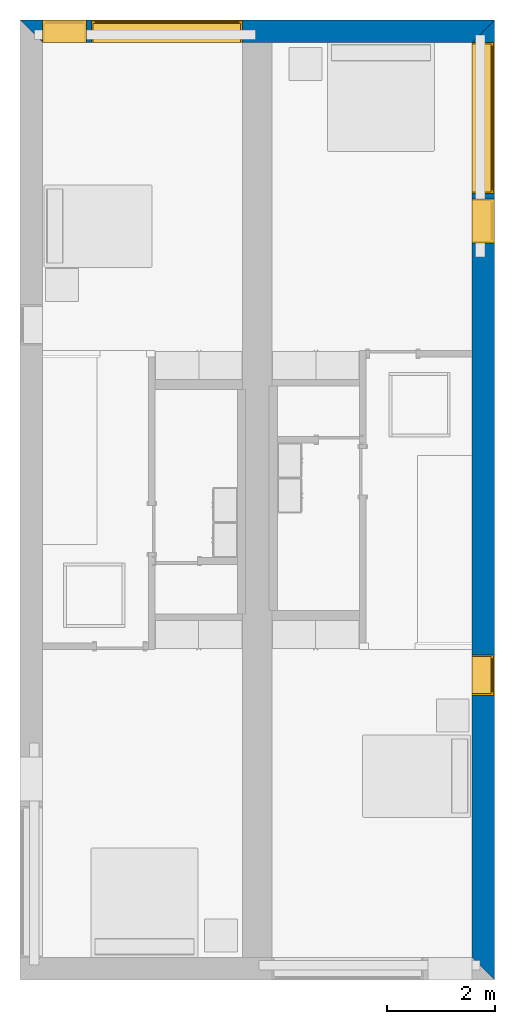
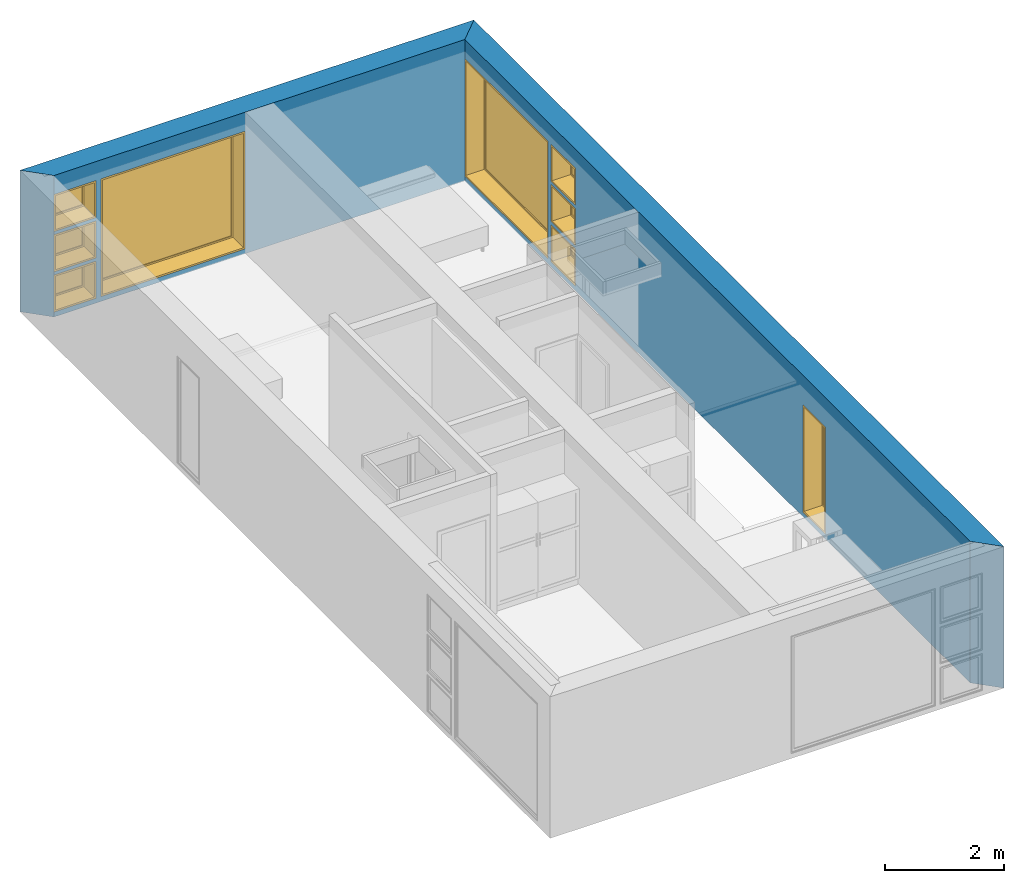
# One storey, part 4 of 14: 9 windows, 2 walls, 9 openings.
"""IFC2X3 building model written with IfcOpenShell, lengths in metres."""

import ifcopenshell
import ifcopenshell.guid

model = None  # the IFC model being written
_history = None  # IfcOwnerHistory: only IFC2X3 demands one
_inside = {}  # id of a spatial element -> (the spatial element, [elements in it])
_under = {}  # id of a project, library or spatial element -> (it, [spatial elements below it])
_declared = {}  # id of a project -> (the project, [libraries it declares])
_typed = {}  # id of a type object -> (the type object, [elements of that type])
_made_of = {}  # id of a material, layer set ... -> (it, [elements and type objects made of it])


def new_model(schema):
    """Start an empty IFC model of exactly this schema.

    Asked for "IFC4X3", IfcOpenShell would pick the latest addendum, in which some entities
    have other attributes; the version numbers below select the first issue.
    IFC2X3 requires an IfcOwnerHistory on every rooted entity: one is made here for all.
    """
    global model, _history
    if schema == "IFC4X3":
        model = ifcopenshell.file(schema_version=(4, 3, 0, 0))
    else:
        model = ifcopenshell.file(schema=schema)
    _inside.clear()
    _under.clear()
    _declared.clear()
    _typed.clear()
    _made_of.clear()
    _history = None
    if model.schema == "IFC2X3":
        org = make("IfcOrganization", Name="unknown")
        user = make(
            "IfcPersonAndOrganization",
            ThePerson=make("IfcPerson", FamilyName="unknown"),
            TheOrganization=org,
        )
        app = make(
            "IfcApplication",
            ApplicationDeveloper=org,
            Version="unknown",
            ApplicationFullName="unknown",
            ApplicationIdentifier="unknown",
        )
        _history = make(
            "IfcOwnerHistory",
            OwningUser=user,
            OwningApplication=app,
            ChangeAction="ADDED",
            CreationDate=0,
        )
    return model


def make(cls, **values):
    """One entity of the class cls with the attributes given. An attribute that is None is left unset."""
    return model.create_entity(
        cls, **{name: value for name, value in values.items() if value is not None}
    )


def entity(cls, *values):
    """Any entity or typed value of the class cls, its attributes in the order of the schema. None: left unset."""
    e = model.create_entity(cls)
    for i, value in enumerate(values):
        if value is not None:
            e[i] = value
    return e


def rooted(cls, **values):
    """An entity with a GlobalId (a new one), such as an element, a storey or a relation."""
    return make(cls, GlobalId=ifcopenshell.guid.new(), OwnerHistory=_history, **values)


def si_unit(unit_type, name, prefix=None):
    """IfcSIUnit, for example si_unit("LENGTHUNIT", "METRE", prefix="MILLI")."""
    return make("IfcSIUnit", UnitType=unit_type, Prefix=prefix, Name=name)


def converted_unit(unit_type, name, factor, base, dimensions=None, offset=None):
    """IfcConversionBasedUnit, such as the inch: factor (a typed value) times the base unit."""
    return make(
        "IfcConversionBasedUnit"
        if offset is None
        else "IfcConversionBasedUnitWithOffset",
        ConversionOffset=offset,
        Dimensions=None
        if dimensions is None
        else entity("IfcDimensionalExponents", *dimensions),
        UnitType=unit_type,
        Name=name,
        ConversionFactor=make(
            "IfcMeasureWithUnit", ValueComponent=factor, UnitComponent=base
        ),
    )


def assignment(units):
    """IfcUnitAssignment: the units of a project."""
    return None if units is None else make("IfcUnitAssignment", Units=units)


def point(xyz):
    """IfcCartesianPoint."""
    return None if xyz is None else make("IfcCartesianPoint", Coordinates=xyz)


def direction(xyz):
    """IfcDirection."""
    return None if xyz is None else make("IfcDirection", DirectionRatios=xyz)


def frame(location, z_axis=None, x_axis=None):
    """IfcAxis2Placement3D, a coordinate frame: its origin and axes. An axis left out is left unset."""
    return make(
        "IfcAxis2Placement3D",
        Location=point(location),
        Axis=direction(z_axis),
        RefDirection=direction(x_axis),
    )


def frame_2d(location, x_axis=None):
    """IfcAxis2Placement2D, a coordinate frame in the plane: its origin and x axis."""
    return make(
        "IfcAxis2Placement2D", Location=point(location), RefDirection=direction(x_axis)
    )


def origin():
    """The frame at (0, 0, 0) with its axes left unset."""
    return frame((0.0, 0.0, 0.0))


def origin_2d_with_axis():
    """The frame at (0, 0) in the plane with the x axis (1, 0) written out."""
    return frame_2d((0.0, 0.0), x_axis=(1.0, 0.0))


def place(relative_to, where):
    """IfcLocalPlacement: puts the frame where relative to a parent placement (None: the world)."""
    return make(
        "IfcLocalPlacement", PlacementRelTo=relative_to, RelativePlacement=where
    )


def context(
    kind, dimensions, precision=None, world=None, true_north=None, identifier=None
):
    """IfcGeometricRepresentationContext, for example the 3D "Model" context."""
    return make(
        "IfcGeometricRepresentationContext",
        ContextIdentifier=identifier,
        ContextType=kind,
        CoordinateSpaceDimension=dimensions,
        Precision=precision,
        WorldCoordinateSystem=world,
        TrueNorth=true_north,
    )


def project(units=None, contexts=None):
    """IfcProject with its units and contexts."""
    return rooted(
        "IfcProject",
        Name="project",
        RepresentationContexts=contexts,
        UnitsInContext=assignment(units),
    )


def spatial(cls, under=None, at=None, **own):
    """A site, building, storey or space (cls), placed at a placement, below another one or the project."""
    s = rooted(cls, ObjectPlacement=at, **own)
    if under is not None:
        _under.setdefault(under.id(), (under, []))[1].append(s)
    return s


def polyline(points):
    """IfcPolyline through the points."""
    return make("IfcPolyline", Points=[point(p) for p in points])


def profile(cls, at=None, kind="AREA", **sizes):
    """A parametric profile (cls). Its sizes go by their IFC names, for example OverallWidth=200.0."""
    return make(cls, ProfileType=kind, Position=at, **sizes)


def rectangle(**sizes):
    """IfcRectangleProfileDef."""
    return profile("IfcRectangleProfileDef", **sizes)


def outline(outer, holes=None, kind="AREA"):
    """IfcArbitraryClosedProfileDef: a profile drawn as a closed curve; with holes, ...WithVoids."""
    if holes is None:
        return make("IfcArbitraryClosedProfileDef", ProfileType=kind, OuterCurve=outer)
    return make(
        "IfcArbitraryProfileDefWithVoids",
        ProfileType=kind,
        OuterCurve=outer,
        InnerCurves=holes,
    )


def extrude(swept, where, along, depth):
    """IfcExtrudedAreaSolid: the profile swept, set in the frame where, extruded along a direction by depth."""
    return make(
        "IfcExtrudedAreaSolid",
        SweptArea=swept,
        Position=where,
        ExtrudedDirection=direction(along),
        Depth=depth,
    )


def shape(context_of_items, identifier, shape_type, items):
    """IfcShapeRepresentation: the items that make up one representation, for example the "Body"."""
    return make(
        "IfcShapeRepresentation",
        ContextOfItems=context_of_items,
        RepresentationIdentifier=identifier,
        RepresentationType=shape_type,
        Items=items,
    )


def source(mapping_origin, context_of_items, identifier, shape_type, items):
    """IfcRepresentationMap: a shape defined once, which mapped items show again and again."""
    return make(
        "IfcRepresentationMap",
        MappingOrigin=mapping_origin,
        MappedRepresentation=shape(context_of_items, identifier, shape_type, items),
    )


def transform(
    local_origin,
    x_axis=None,
    y_axis=None,
    z_axis=None,
    scale=None,
    scale2=None,
    scale3=None,
    uniform=True,
):
    """IfcCartesianTransformationOperator3D, or its non-uniform kind. x_axis, y_axis, z_axis: its Axis1, 2, 3."""
    if uniform:
        return make(
            "IfcCartesianTransformationOperator3D",
            Axis1=direction(x_axis),
            Axis2=direction(y_axis),
            LocalOrigin=point(local_origin),
            Scale=scale,
            Axis3=direction(z_axis),
        )
    return make(
        "IfcCartesianTransformationOperator3DnonUniform",
        Axis1=direction(x_axis),
        Axis2=direction(y_axis),
        LocalOrigin=point(local_origin),
        Scale=scale,
        Axis3=direction(z_axis),
        Scale2=scale2,
        Scale3=scale3,
    )


def mapped(mapping_source, mapping_target):
    """IfcMappedItem: shows the shape of a source again, moved by a transform."""
    return make(
        "IfcMappedItem", MappingSource=mapping_source, MappingTarget=mapping_target
    )


def material(Name=None, Category=None):
    """IfcMaterial."""
    return make("IfcMaterial", Name=Name, Category=Category)


def layer(
    of_material, thickness, ventilated=None, Name=None, Category=None, Priority=None
):
    """IfcMaterialLayer: one layer of a wall or slab, of a material (None: an air gap)."""
    return make(
        "IfcMaterialLayer",
        Material=of_material,
        LayerThickness=thickness,
        IsVentilated=ventilated,
        Name=Name,
        Category=Category,
        Priority=Priority,
    )


def layer_set(layers, Name=None):
    """IfcMaterialLayerSet."""
    return make("IfcMaterialLayerSet", MaterialLayers=layers, LayerSetName=Name)


def layer_usage(for_layer_set, set_direction, sense, offset, extent=None):
    """IfcMaterialLayerSetUsage: how a layer set lies in its element."""
    return make(
        "IfcMaterialLayerSetUsage",
        ForLayerSet=for_layer_set,
        LayerSetDirection=set_direction,
        DirectionSense=sense,
        OffsetFromReferenceLine=offset,
        ReferenceExtent=extent,
    )


def made_of(thing, what):
    """Note that an element or type object is made of a material, layer set ...; save() writes the relation."""
    if what is not None:
        _made_of.setdefault(what.id(), (what, []))[1].append(thing)
    return thing


def type_object(cls, material=None, **own):
    """A type object (cls), such as IfcWallType, which elements share."""
    return made_of(rooted(cls, **own), material)


def type_shapes(of_type, sources):
    """Give a type object the sources (RepresentationMaps) that its elements show as mapped items."""
    of_type.RepresentationMaps = sources


def element(
    cls,
    number,
    at=None,
    inside=None,
    cuts=None,
    type_object=None,
    material=None,
    context=None,
    identifier="Body",
    shape_type=None,
    held_by="IfcProductDefinitionShape",
    body=None,
    shapes=None,
    **own,
):
    """One element of the class cls, such as IfcWall. Its Tag is "e" and its number.

    at: its placement. inside: the storey or other place that contains it. cuts: it is an
    opening in that element (IfcRelVoidsElement). A single representation is given by context,
    identifier, shape_type and body (its items); several are given by shapes. held_by: the class
    of the entity that holds the representations. save() writes the other relations.
    """
    e = rooted(cls, Tag="e%d" % number, ObjectPlacement=at, **own)
    if body is not None:
        shapes = [shape(context, identifier, shape_type, body)]
    if shapes is not None:
        e.Representation = make(held_by, Representations=shapes)
    if inside is not None:
        _inside.setdefault(inside.id(), (inside, []))[1].append(e)
    if cuts is not None:
        rooted(
            "IfcRelVoidsElement", RelatingBuildingElement=cuts, RelatedOpeningElement=e
        )
    if type_object is not None:
        _typed.setdefault(type_object.id(), (type_object, []))[1].append(e)
    return made_of(e, material)


def fill(opening, filler):
    """IfcRelFillsElement: the door or window that sits in an opening."""
    return rooted(
        "IfcRelFillsElement",
        RelatingOpeningElement=opening,
        RelatedBuildingElement=filler,
    )


def aggregate(whole, parts):
    """IfcRelAggregates: a whole, such as a stair, and the parts it consists of."""
    return rooted("IfcRelAggregates", RelatingObject=whole, RelatedObjects=parts)


def save(model, path):
    """Write the relations noted so far, then the file.

    IfcRelAggregates (storeys below a building ...), IfcRelContainedInSpatialStructure (elements
    in a storey), IfcRelDefinesByType, IfcRelAssociatesMaterial and IfcRelDeclares: one each for
    every whole, place, type object, material and project.
    """
    for whole, parts in _under.values():
        aggregate(whole, parts)
    for where, things in _inside.values():
        rooted(
            "IfcRelContainedInSpatialStructure",
            RelatedElements=things,
            RelatingStructure=where,
        )
    for kind, things in _typed.values():
        rooted("IfcRelDefinesByType", RelatedObjects=things, RelatingType=kind)
    for what, things in _made_of.values():
        rooted("IfcRelAssociatesMaterial", RelatedObjects=things, RelatingMaterial=what)
    for by, libraries in _declared.values():
        rooted("IfcRelDeclares", RelatingContext=by, RelatedDefinitions=libraries)
    model.write(path)


model = new_model("IFC2X3")

# Units and contexts
model_context = context("Model", 3, precision=1e-09, world=origin())
plan_context = context("Plan", 3, precision=1e-09, world=origin())
ifc_project = project(units=[si_unit("LENGTHUNIT", "METRE"), si_unit("AREAUNIT", "SQUARE_METRE"), si_unit("VOLUMEUNIT", "CUBIC_METRE"), converted_unit("PLANEANGLEUNIT", "DEGREE", entity("IfcRatioMeasure", 0.01745329251994328), si_unit("PLANEANGLEUNIT", "RADIAN"), dimensions=[0, 0, 0, 0, 0, 0, 0]), si_unit("TIMEUNIT", "SECOND")], contexts=[model_context, plan_context])

# Site, building, storey
site_placement = place(None, origin())
site = spatial("IfcSite", under=ifc_project, at=site_placement, CompositionType="ELEMENT")
building_placement = place(site_placement, origin())
building = spatial("IfcBuilding", under=site, at=building_placement, CompositionType="ELEMENT")
storey_placement = place(building_placement, frame((0.0, 0.0, 3.100000000000378)))
storey = spatial("IfcBuildingStorey", under=building, at=storey_placement, Name="Level 2", CompositionType="ELEMENT", Elevation=3.100000000000378)

# Wall, openings, windows
ifc_material_1 = material(Name="Masonry - Brick")
ifc_layer_1 = layer(ifc_material_1, 0.092)
ifc_material_2 = material(Name="Misc. Air Layers - Air Space")
ifc_layer_2 = layer(ifc_material_2, 0.025)
ifc_material_3 = material(Name="Insulation / Thermal Barriers - Rigid insulation")
ifc_layer_3 = layer(ifc_material_3, 0.05)
ifc_material_4 = material(Name="Masonry - Concrete Block")
ifc_layer_4 = layer(ifc_material_4, 0.193)
ifc_material_5 = material(Name="Metal - Stud Layer")
ifc_layer_5 = layer(ifc_material_5, 0.041)
ifc_material_6 = material(Name="Plasterboard")
ifc_layer_6 = layer(ifc_material_6, 0.016)
ifc_layer_set = layer_set([ifc_layer_1, ifc_layer_2, ifc_layer_3, ifc_layer_4, ifc_layer_5, ifc_layer_6], Name="Basic Wall:Exterior - Brick on Block")
ifc_layer_usage = layer_usage(ifc_layer_set, "AXIS2", "NEGATIVE", 0.2085000000000001)
wall_1_placement = place(storey_placement, frame((8.5915, 0.0, 0.0), z_axis=(0.0, 0.0, 1.0), x_axis=(0.0, -1.0, 0.0)))
wall_1 = element("IfcWallStandardCase", 1, at=wall_1_placement, inside=storey, material=ifc_layer_usage, Name="Basic Wall:Exterior - Brick on Block", ObjectType="Basic Wall:Exterior - Brick on Block", context=model_context, shape_type="SweptSolid", body=[
    extrude(outline(polyline([(17.38299999999997, -0.2084999999999999), (17.79999999999997, 0.2085000000000002), (0.0, 0.2085000000000002), (0.4169999999999991, -0.2085000000000007), (6.125999999999979, -0.2084999999999999), (6.24999999999998, -0.2084999999999997), (17.38299999999997, -0.2084999999999999)])), origin(), (0.0, 0.0, 1.0), 2.900000000000012),
])
opening_1_placement = place(wall_1_placement, frame((11.774, -0.2085000000000172, 0.09999999999981862)))
opening_1 = element("IfcOpeningElement", 2, at=opening_1_placement, cuts=wall_1, ObjectType="Opening", context=model_context, shape_type="SweptSolid", body=[
    extrude(rectangle(XDim=2.199999999999996, YDim=0.7499999999999996, at=frame_2d((1.099999999999999, 0.3749999999999987), x_axis=(1.0, 0.0))), frame((0.0, 0.0, 0.0), z_axis=(0.0, 1.0, 0.0), x_axis=(0.0, 0.0, 1.0)), (0.0, 0.0, 1.0), 0.4170000000000001),
])
opening_2_placement = place(wall_1_placement, frame((3.317000000000042, -0.2085000000000054, 0.9254999999998184)))
opening_2 = element("IfcOpeningElement", 3, at=opening_2_placement, cuts=wall_1, ObjectType="Opening", context=model_context, shape_type="SweptSolid", body=[
    extrude(rectangle(XDim=0.7590000000000007, YDim=0.8189999999999998, at=frame_2d((0.3795000000000003, 0.4094999999999999), x_axis=(-1.0, 0.0))), frame((0.0, 0.0, 0.0), z_axis=(0.0, 1.0, 0.0), x_axis=(0.0, 0.0, 1.0)), (0.0, 0.0, 1.0), 0.4170000000000001),
])
opening_3_placement = place(wall_1_placement, frame((0.4170000000000265, -0.2084999999999953, 0.09999999999981862)))
opening_3 = element("IfcOpeningElement", 4, at=opening_3_placement, cuts=wall_1, ObjectType="Opening", context=model_context, shape_type="SweptSolid", body=[
    extrude(rectangle(XDim=2.409999999999996, YDim=2.8, at=frame_2d((1.204999999999998, 1.4), x_axis=(1.0, 0.0))), frame((0.0, 0.0, 0.0), z_axis=(0.0, 1.0, 0.0), x_axis=(0.0, 0.0, 1.0)), (0.0, 0.0, 1.0), 0.4170000000000001),
])
opening_4_placement = place(wall_1_placement, frame((3.317000000000027, -0.2085000000000039, 1.750999999999819)))
opening_4 = element("IfcOpeningElement", 5, at=opening_4_placement, cuts=wall_1, ObjectType="Opening", context=model_context, shape_type="SweptSolid", body=[
    extrude(rectangle(XDim=0.7589999999999981, YDim=0.8189999999999995, at=frame_2d((0.379499999999999, 0.4094999999999998), x_axis=(1.0, 0.0))), frame((0.0, 0.0, 0.0), z_axis=(0.0, 1.0, 0.0), x_axis=(0.0, 0.0, 1.0)), (0.0, 0.0, 1.0), 0.4170000000000001),
])
opening_5_placement = place(wall_1_placement, frame((3.317000000000027, -0.2085000000000039, 0.09999999999981862)))
opening_5 = element("IfcOpeningElement", 6, at=opening_5_placement, cuts=wall_1, ObjectType="Opening", context=model_context, shape_type="SweptSolid", body=[
    extrude(rectangle(XDim=0.7589999999999981, YDim=0.8189999999999995, at=frame_2d((0.3794999999999993, 0.4094999999999998), x_axis=(1.0, 0.0))), frame((0.0, 0.0, 0.0), z_axis=(0.0, 1.0, 0.0), x_axis=(0.0, 0.0, 1.0)), (0.0, 0.0, 1.0), 0.4170000000000001),
])
window_style_1 = type_object("IfcWindowStyle", Name="819mm x 759mm", ConstructionType="NOTDEFINED", OperationType="NOTDEFINED", ParameterTakesPrecedence=False, Sizeable=False)
shared_shape_1 = source(origin(), model_context, "Body", "SweptSolid", [
    extrude(rectangle(XDim=0.01199999999999998, YDim=0.6929999999999971, at=origin_2d_with_axis()), frame((0.4095000000000068, 0.3759999999999988, 0.06299999999998514), z_axis=(0.0, 0.0, 1.0), x_axis=(0.0, -1.0, 0.0)), (0.0, 0.0, 1.0), 0.6330000000000073),
    extrude(outline(polyline([(-0.3904999999999999, -0.3605000000000028), (0.3904999999999999, -0.3605000000000028), (0.3904999999999999, 0.3605000000000027), (-0.3904999999999999, 0.3605000000000027), (-0.3904999999999999, -0.3605000000000028)]), holes=[polyline([(-0.3464999999999996, -0.3165000000000033), (-0.3464999999999996, 0.316500000000004), (0.3464999999999974, 0.316500000000004), (0.3464999999999974, -0.3165000000000033), (-0.3464999999999996, -0.3165000000000033)])]), frame((0.4095000000000078, 0.3539999999999714, 0.3794999999999891), z_axis=(0.0, 1.0, 0.0), x_axis=(1.0, 0.0, 0.0)), (0.0, 0.0, 1.0), 0.04400000000002743),
    extrude(outline(polyline([(-0.4094999999999998, -0.3794999999999972), (0.4094999999999998, -0.3794999999999972), (0.4094999999999998, 0.3794999999999971), (-0.4094999999999998, 0.3794999999999971), (-0.4094999999999998, -0.3794999999999972)]), holes=[polyline([(-0.3905000000000011, -0.3604999999999823), (-0.3905000000000012, 0.3605000000000231), (0.3904999999999986, 0.3605000000000231), (0.3904999999999987, -0.3604999999999823), (-0.3905000000000011, -0.3604999999999823)])]), frame((0.4095000000000091, 0.3539999999999714, 0.3795000000000096), z_axis=(0.0, 1.0, 0.0), x_axis=(1.0, 0.0, 0.0)), (0.0, 0.0, 1.0), 0.06300000000002744),
    extrude(outline(polyline([(-0.4095000000000002, -0.3794999999999967), (0.4095000000000002, -0.3794999999999967), (0.4095000000000002, 0.3794999999999966), (-0.4095000000000002, 0.3794999999999966), (-0.4095000000000002, -0.3794999999999967)]), holes=[polyline([(-0.3774999999999999, -0.3474999999999832), (-0.3774999999999999, 0.3475000000000212), (0.3775000000000001, 0.3475000000000212), (0.3775000000000001, -0.3474999999999832), (-0.3774999999999999, -0.3474999999999832)])]), frame((0.4095000000000096, 0.0, 0.379500000000009), z_axis=(0.0, 1.0, 0.0), x_axis=(1.0, 0.0, 0.0)), (0.0, 0.0, 1.0), 0.3539999999999727),
])
type_shapes(window_style_1, [shared_shape_1])
window_1_placement = place(opening_5_placement, origin())
window_1 = element("IfcWindow", 7, at=window_1_placement, inside=storey, type_object=window_style_1, ObjectType="819mm x 759mm", OverallHeight=0.7589999999999986, OverallWidth=0.8189999999999995, context=model_context, shape_type="MappedRepresentation", body=[
    mapped(shared_shape_1, transform((0.0, 0.0, 0.0), scale=1.0)),
])
fill(opening_5, window_1)
window_2_placement = place(opening_4_placement, origin())
window_2 = element("IfcWindow", 8, at=window_2_placement, inside=storey, type_object=window_style_1, ObjectType="819mm x 759mm", OverallHeight=0.758999999999998, OverallWidth=0.8189999999999995, context=model_context, shape_type="MappedRepresentation", body=[
    mapped(shared_shape_1, transform((0.0, 0.0, 0.0), scale=1.0)),
])
fill(opening_4, window_2)
window_style_2 = type_object("IfcWindowStyle", Name="2800mm x 2410mm", ConstructionType="NOTDEFINED", OperationType="NOTDEFINED", ParameterTakesPrecedence=False, Sizeable=False)
shared_shape_2 = source(origin(), model_context, "Body", "SweptSolid", [
    extrude(rectangle(XDim=0.01199999999999998, YDim=2.673999999999997, at=origin_2d_with_axis()), frame((1.400000000000007, 0.3759999999999956, 0.06299999999998514), z_axis=(0.0, 0.0, 1.0), x_axis=(0.0, -1.0, 0.0)), (0.0, 0.0, 1.0), 2.284000000000005),
    extrude(outline(polyline([(-1.381, -1.186000000000001), (1.381, -1.186000000000001), (1.381, 1.186000000000001), (-1.381, 1.186000000000001), (-1.381, -1.186000000000001)]), holes=[polyline([(-1.336999999999999, -1.142000000000002), (-1.336999999999999, 1.142000000000003), (1.336999999999997, 1.142000000000003), (1.336999999999997, -1.142000000000002), (-1.336999999999999, -1.142000000000002)])]), frame((1.400000000000008, 0.3539999999999681, 1.204999999999988), z_axis=(0.0, 1.0, 0.0), x_axis=(1.0, 0.0, 0.0)), (0.0, 0.0, 1.0), 0.04400000000002743),
    extrude(outline(polyline([(-1.4, -1.204999999999996), (1.4, -1.204999999999996), (1.4, 1.204999999999996), (-1.4, 1.204999999999996), (-1.4, -1.204999999999996)]), holes=[polyline([(-1.381000000000001, -1.185999999999981), (-1.381000000000001, 1.186000000000022), (1.380999999999999, 1.186000000000022), (1.380999999999999, -1.185999999999981), (-1.381000000000001, -1.185999999999981)])]), frame((1.400000000000009, 0.3539999999999681, 1.205000000000009), z_axis=(0.0, 1.0, 0.0), x_axis=(1.0, 0.0, 0.0)), (0.0, 0.0, 1.0), 0.06300000000002744),
    extrude(outline(polyline([(-1.4, -1.204999999999995), (1.4, -1.204999999999995), (1.4, 1.204999999999995), (-1.4, 1.204999999999995), (-1.4, -1.204999999999995)]), holes=[polyline([(-1.368, -1.172999999999982), (-1.368, 1.17300000000002), (1.368, 1.17300000000002), (1.367999999999999, -1.172999999999982), (-1.368, -1.172999999999982)])]), frame((1.40000000000001, 0.0, 1.205000000000008), z_axis=(0.0, 1.0, 0.0), x_axis=(1.0, 0.0, 0.0)), (0.0, 0.0, 1.0), 0.3539999999999727),
])
type_shapes(window_style_2, [shared_shape_2])
window_3_placement = place(opening_3_placement, origin())
window_3 = element("IfcWindow", 9, at=window_3_placement, inside=storey, type_object=window_style_2, ObjectType="2800mm x 2410mm", OverallHeight=2.409999999999996, OverallWidth=2.8, context=model_context, shape_type="MappedRepresentation", body=[
    mapped(shared_shape_2, transform((0.0, 0.0, 0.0), scale=1.0)),
])
fill(opening_3, window_3)
window_style_3 = type_object("IfcWindowStyle", Name="750mm x 2200mm", ConstructionType="NOTDEFINED", OperationType="NOTDEFINED", ParameterTakesPrecedence=False, Sizeable=False)
shared_shape_3 = source(origin(), model_context, "Body", "SweptSolid", [
    extrude(rectangle(XDim=0.01199999999999998, YDim=0.623999999999997, at=origin_2d_with_axis()), frame((0.375000000000007, 0.3759999999999988, 0.06299999999998514), z_axis=(0.0, 0.0, 1.0), x_axis=(0.0, -1.0, 0.0)), (0.0, 0.0, 1.0), 2.074000000000006),
    extrude(outline(polyline([(-0.3559999999999999, -1.081000000000002), (0.3559999999999999, -1.081000000000002), (0.3559999999999999, 1.081000000000002), (-0.3559999999999999, 1.081000000000002), (-0.3559999999999999, -1.081000000000002)]), holes=[polyline([(-0.3119999999999996, -1.037000000000002), (-0.3119999999999996, 1.037000000000003), (0.3119999999999975, 1.037000000000003), (0.3119999999999975, -1.037000000000002), (-0.3119999999999996, -1.037000000000002)])]), frame((0.3750000000000081, 0.3539999999999715, 1.099999999999989), z_axis=(0.0, 1.0, 0.0), x_axis=(1.0, 0.0, 0.0)), (0.0, 0.0, 1.0), 0.04400000000002743),
    extrude(outline(polyline([(-0.3749999999999997, -1.099999999999996), (0.3749999999999997, -1.099999999999996), (0.3749999999999997, 1.099999999999996), (-0.3749999999999997, 1.099999999999996), (-0.3749999999999997, -1.099999999999996)]), holes=[polyline([(-0.3560000000000012, -1.080999999999981), (-0.3560000000000013, 1.081000000000022), (0.3559999999999985, 1.081000000000022), (0.3559999999999986, -1.080999999999981), (-0.3560000000000012, -1.080999999999981)])]), frame((0.3750000000000094, 0.3539999999999715, 1.100000000000009), z_axis=(0.0, 1.0, 0.0), x_axis=(1.0, 0.0, 0.0)), (0.0, 0.0, 1.0), 0.06300000000002744),
    extrude(outline(polyline([(-0.3750000000000001, -1.099999999999996), (0.3750000000000001, -1.099999999999996), (0.3750000000000001, 1.099999999999996), (-0.3750000000000001, 1.099999999999996), (-0.3750000000000001, -1.099999999999996)]), holes=[polyline([(-0.3429999999999999, -1.067999999999982), (-0.3429999999999999, 1.06800000000002), (0.3430000000000001, 1.06800000000002), (0.3430000000000001, -1.067999999999982), (-0.3429999999999999, -1.067999999999982)])]), frame((0.3750000000000099, 0.0, 1.100000000000008), z_axis=(0.0, 1.0, 0.0), x_axis=(1.0, 0.0, 0.0)), (0.0, 0.0, 1.0), 0.3539999999999727),
])
type_shapes(window_style_3, [shared_shape_3])
window_4_placement = place(opening_1_placement, origin())
window_4 = element("IfcWindow", 10, at=window_4_placement, inside=storey, type_object=window_style_3, ObjectType="750mm x 2200mm", OverallHeight=2.199999999999997, OverallWidth=0.7499999999999984, context=model_context, shape_type="MappedRepresentation", body=[
    mapped(shared_shape_3, transform((0.0, 0.0, 0.0), scale=1.0)),
])
fill(opening_1, window_4)
window_style_4 = type_object("IfcWindowStyle", Name="819mm x 759mm", ConstructionType="NOTDEFINED", OperationType="NOTDEFINED", ParameterTakesPrecedence=False, Sizeable=False)
shared_shape_4 = source(origin(), model_context, "Body", "SweptSolid", [
    extrude(rectangle(XDim=0.01269999999999999, YDim=0.6919999999999978, at=origin_2d_with_axis()), frame((0.4095000000000003, 0.3757750000000001, 0.06350000000000397), z_axis=(0.0, 0.0, 1.0), x_axis=(0.0, 1.0, 0.0)), (0.0, 0.0, 1.0), 0.6320000000000041),
    extrude(outline(polyline([(-0.3904499999999989, -0.3604500000000012), (0.3904499999999989, -0.3604500000000012), (0.3904499999999989, 0.3604500000000012), (-0.3904499999999989, 0.3604500000000012), (-0.3904499999999989, -0.3604500000000012)]), holes=[polyline([(-0.3459999999999978, -0.3160000000000016), (-0.3459999999999978, 0.3160000000000026), (0.346, 0.3160000000000026), (0.346, -0.3160000000000016), (-0.3459999999999978, -0.3160000000000016)])]), frame((0.4094999999999992, 0.3535500000000001, 0.3795000000000066), z_axis=(0.0, 1.0, 0.0), x_axis=(1.0, 0.0, 0.0)), (0.0, 0.0, 1.0), 0.04445),
    extrude(outline(polyline([(-0.4094999999999992, -0.3795000000000012), (0.4094999999999992, -0.3795000000000012), (0.4094999999999992, 0.3795000000000012), (-0.4094999999999992, 0.3795000000000012), (-0.4094999999999992, -0.3795000000000012)]), holes=[polyline([(-0.3777500000000001, -0.3477499999999997), (-0.3777500000000001, 0.3477500000000008), (0.3777499999999982, 0.3477500000000008), (0.3777499999999982, -0.3477499999999997), (-0.3777500000000001, -0.3477499999999997)])]), frame((0.4095000000000007, 0.0, 0.3795000000000077), z_axis=(0.0, 1.0, 0.0), x_axis=(1.0, 0.0, 0.0)), (0.0, 0.0, 1.0), 0.3535500000000001),
    extrude(outline(polyline([(-0.3795000000000017, -0.4094999999999995), (0.3795000000000017, -0.4094999999999995), (0.3795000000000017, 0.4094999999999995), (-0.3795000000000017, 0.4094999999999995), (-0.3795000000000017, -0.4094999999999995)]), holes=[polyline([(-0.3604500000000023, -0.3904499999999987), (-0.3604500000000023, 0.3904499999999997), (0.3604500000000017, 0.3904499999999997), (0.3604500000000017, -0.3904499999999988), (-0.3604500000000023, -0.3904499999999987)])]), frame((0.4095000000000004, 0.3535500000000001, 0.3795000000000071), z_axis=(0.0, 1.0, 0.0), x_axis=(0.0, 0.0, -1.0)), (0.0, 0.0, 1.0), 0.06345),
])
type_shapes(window_style_4, [shared_shape_4])
window_5_placement = place(opening_2_placement, origin())
window_5 = element("IfcWindow", 11, at=window_5_placement, inside=storey, type_object=window_style_4, ObjectType="819mm x 759mm", OverallHeight=0.7590000000000007, OverallWidth=0.8190000000000001, context=model_context, shape_type="MappedRepresentation", body=[
    mapped(shared_shape_4, transform((0.0, 0.0, 0.0), scale=1.0)),
])
fill(opening_2, window_5)

wall_2_placement = place(storey_placement, frame((0.0, -0.2085000000000001, 0.0)))
wall_2 = element("IfcWallStandardCase", 12, at=wall_2_placement, inside=storey, material=ifc_layer_usage, Name="Basic Wall:Exterior - Brick on Block", ObjectType="Basic Wall:Exterior - Brick on Block", context=model_context, shape_type="SweptSolid", body=[
    extrude(outline(polyline([(8.383000000000001, -0.2085000000000001), (8.8, 0.2085000000000001), (0.0, 0.2085000000000001), (0.4170000000000014, -0.2085000000000001), (4.125000000000002, -0.2085000000000001), (4.675000000000002, -0.2085000000000001), (8.383000000000001, -0.2085000000000001)])), origin(), (0.0, 0.0, 1.0), 2.900000000000012),
])
opening_6_placement = place(wall_2_placement, frame((0.417000000000015, -0.2085000000000014, 0.9254999999998172)))
opening_6 = element("IfcOpeningElement", 13, at=opening_6_placement, cuts=wall_2, ObjectType="Opening", context=model_context, shape_type="SweptSolid", body=[
    extrude(rectangle(XDim=0.7590000000000007, YDim=0.8189999999999998, at=frame_2d((0.3795000000000003, 0.4094999999999999), x_axis=(-1.0, 0.0))), frame((0.0, 0.0, 0.0), z_axis=(0.0, 1.0, 0.0), x_axis=(0.0, 0.0, 1.0)), (0.0, 0.0, 1.0), 0.4170000000000001),
])
opening_7_placement = place(wall_2_placement, frame((0.4170000000000003, -0.2085000000000001, 0.0999999999998235)))
opening_7 = element("IfcOpeningElement", 14, at=opening_7_placement, cuts=wall_2, ObjectType="Opening", context=model_context, shape_type="SweptSolid", body=[
    extrude(rectangle(XDim=0.7589999999999981, YDim=0.8189999999999996, at=frame_2d((0.379499999999999, 0.4095), x_axis=(1.0, 0.0))), frame((0.0, 0.0, 0.0), z_axis=(0.0, 1.0, 0.0), x_axis=(0.0, 0.0, 1.0)), (0.0, 0.0, 1.0), 0.4170000000000001),
])
opening_8_placement = place(wall_2_placement, frame((1.325, -0.2084999999999999, 0.09999999999981862)))
opening_8 = element("IfcOpeningElement", 15, at=opening_8_placement, cuts=wall_2, ObjectType="Opening", context=model_context, shape_type="SweptSolid", body=[
    extrude(rectangle(XDim=2.409999999999996, YDim=2.8, at=frame_2d((1.204999999999998, 1.4), x_axis=(1.0, 0.0))), frame((0.0, 0.0, 0.0), z_axis=(0.0, 1.0, 0.0), x_axis=(0.0, 0.0, 1.0)), (0.0, 0.0, 1.0), 0.4170000000000001),
])
opening_9_placement = place(wall_2_placement, frame((0.4170000000000002, -0.2085000000000001, 1.750999999999816)))
opening_9 = element("IfcOpeningElement", 16, at=opening_9_placement, cuts=wall_2, ObjectType="Opening", context=model_context, shape_type="SweptSolid", body=[
    extrude(rectangle(XDim=0.7589999999999981, YDim=0.8189999999999995, at=frame_2d((0.3794999999999993, 0.4094999999999998), x_axis=(1.0, 0.0))), frame((0.0, 0.0, 0.0), z_axis=(0.0, 1.0, 0.0), x_axis=(0.0, 0.0, 1.0)), (0.0, 0.0, 1.0), 0.4170000000000001),
])
window_6_placement = place(opening_7_placement, origin())
window_6 = element("IfcWindow", 17, at=window_6_placement, inside=storey, type_object=window_style_1, ObjectType="819mm x 759mm", OverallHeight=0.758999999999998, OverallWidth=0.8189999999999998, context=model_context, shape_type="MappedRepresentation", body=[
    mapped(shared_shape_1, transform((0.0, 0.0, 0.0), scale=1.0)),
])
fill(opening_7, window_6)
window_7_placement = place(opening_9_placement, origin())
window_7 = element("IfcWindow", 18, at=window_7_placement, inside=storey, type_object=window_style_1, ObjectType="819mm x 759mm", OverallHeight=0.7589999999999986, OverallWidth=0.8189999999999995, context=model_context, shape_type="MappedRepresentation", body=[
    mapped(shared_shape_1, transform((0.0, 0.0, 0.0), scale=1.0)),
])
fill(opening_9, window_7)
window_8_placement = place(opening_8_placement, origin())
window_8 = element("IfcWindow", 19, at=window_8_placement, inside=storey, type_object=window_style_2, ObjectType="2800mm x 2410mm", OverallHeight=2.409999999999996, OverallWidth=2.8, context=model_context, shape_type="MappedRepresentation", body=[
    mapped(shared_shape_2, transform((0.0, 0.0, 0.0), scale=1.0)),
])
fill(opening_8, window_8)
window_9_placement = place(opening_6_placement, origin())
window_9 = element("IfcWindow", 20, at=window_9_placement, inside=storey, type_object=window_style_4, ObjectType="819mm x 759mm", OverallHeight=0.7590000000000007, OverallWidth=0.819, context=model_context, shape_type="MappedRepresentation", body=[
    mapped(shared_shape_4, transform((0.0, 0.0, 0.0), scale=1.0)),
])
fill(opening_6, window_9)

save(model, "model.ifc")
